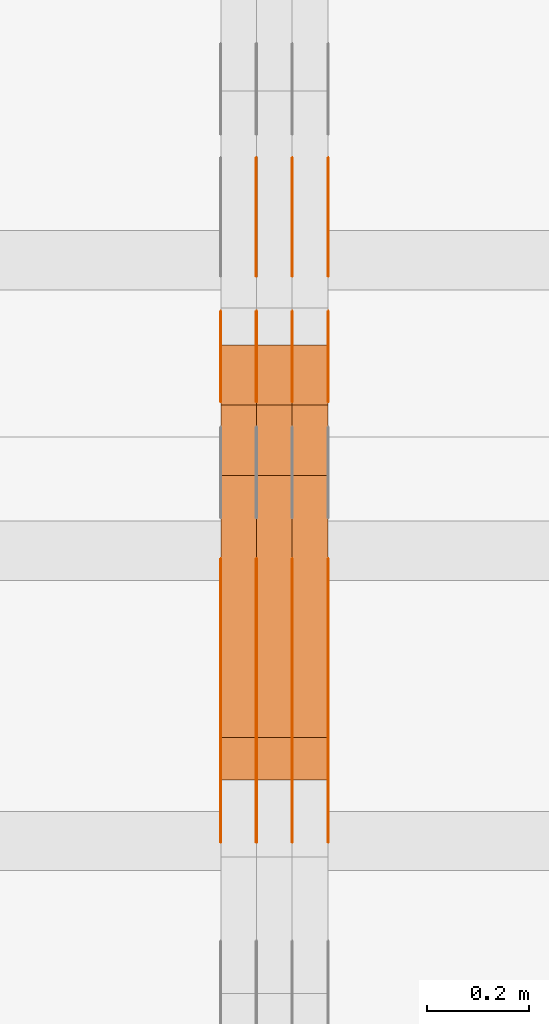
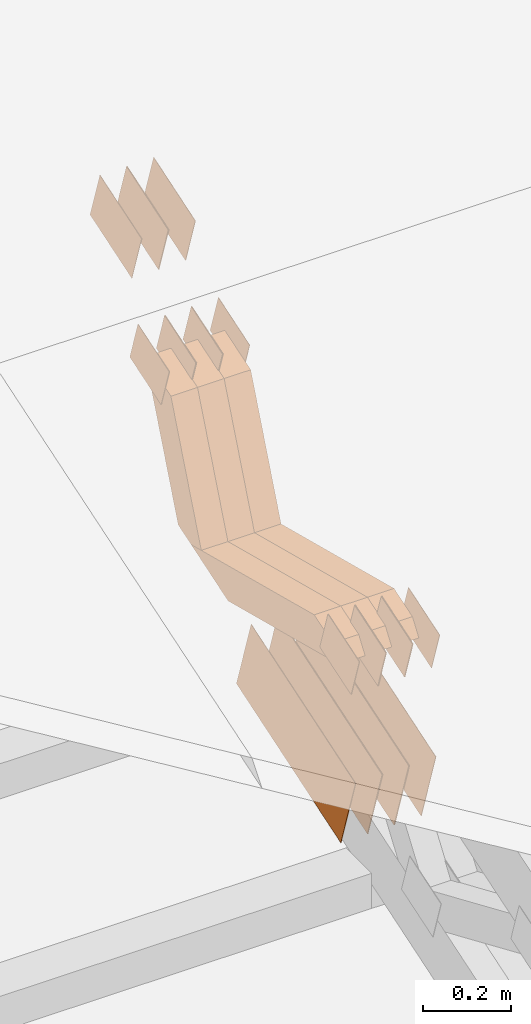
# One storey, part 119 of 385: 28 proxies.
"""IFC2X3 building model written with IfcOpenShell, lengths in millimetres."""

from ifc_helpers import new_model, entity, si_unit, converted_unit, derived_unit, direction, frame, origin, place, context, subcontext, project, spatial, polyline, outline, extrude, source, transform, mapped, material, type_object, type_shapes, element, save


model = new_model("IFC2X3")

# Units and contexts
model_context = context("Model", 3, precision=0.01, world=origin(), true_north=direction((6.12303176911189e-17, 1.0)))
body_context = subcontext(model_context, "Body", "Model", "MODEL_VIEW")
ifc_project = project(units=[si_unit("LENGTHUNIT", "METRE", prefix="MILLI"), si_unit("AREAUNIT", "SQUARE_METRE"), si_unit("VOLUMEUNIT", "CUBIC_METRE"), converted_unit("PLANEANGLEUNIT", "DEGREE", entity("IfcRatioMeasure", 0.0174532925199433), si_unit("PLANEANGLEUNIT", "RADIAN"), dimensions=[0, 0, 0, 0, 0, 0, 0]), si_unit("MASSUNIT", "GRAM", prefix="KILO"), derived_unit("MASSDENSITYUNIT", [(si_unit("MASSUNIT", "GRAM", prefix="KILO"), 1), (si_unit("LENGTHUNIT", "METRE"), -3)]), si_unit("TIMEUNIT", "SECOND"), si_unit("FREQUENCYUNIT", "HERTZ"), si_unit("THERMODYNAMICTEMPERATUREUNIT", "DEGREE_CELSIUS"), derived_unit("THERMALTRANSMITTANCEUNIT", [(si_unit("MASSUNIT", "GRAM", prefix="KILO"), 1), (si_unit("THERMODYNAMICTEMPERATUREUNIT", "KELVIN"), -1), (si_unit("TIMEUNIT", "SECOND"), -3)]), derived_unit("VOLUMETRICFLOWRATEUNIT", [(si_unit("LENGTHUNIT", "METRE"), 3), (si_unit("TIMEUNIT", "SECOND"), -1)]), si_unit("ELECTRICCURRENTUNIT", "AMPERE"), si_unit("ELECTRICVOLTAGEUNIT", "VOLT"), si_unit("POWERUNIT", "WATT"), si_unit("FORCEUNIT", "NEWTON", prefix="KILO"), si_unit("ILLUMINANCEUNIT", "LUX"), si_unit("LUMINOUSFLUXUNIT", "LUMEN"), si_unit("LUMINOUSINTENSITYUNIT", "CANDELA"), derived_unit("USERDEFINED", [(si_unit("MASSUNIT", "GRAM", prefix="KILO"), -1), (si_unit("LENGTHUNIT", "METRE"), -2), (si_unit("TIMEUNIT", "SECOND"), 3), (si_unit("LUMINOUSFLUXUNIT", "LUMEN"), 1)]), derived_unit("LINEARVELOCITYUNIT", [(si_unit("LENGTHUNIT", "METRE"), 1), (si_unit("TIMEUNIT", "SECOND"), -1)]), si_unit("PRESSUREUNIT", "PASCAL"), derived_unit("USERDEFINED", [(si_unit("LENGTHUNIT", "METRE"), -2), (si_unit("MASSUNIT", "GRAM", prefix="KILO"), 1), (si_unit("TIMEUNIT", "SECOND"), -2)])], contexts=[model_context])

# Site, building, storey
site_placement = place(None, origin())
site = spatial("IfcSite", under=ifc_project, at=site_placement, CompositionType="ELEMENT")
building_placement = place(site_placement, origin())
building = spatial("IfcBuilding", under=site, at=building_placement, CompositionType="ELEMENT")
storey_placement = place(building_placement, origin())
storey = spatial("IfcBuildingStorey", under=building, at=storey_placement, Name="Default", CompositionType="ELEMENT", Elevation=0.0)

# Proxies
ifc_material_1 = material(Name="IfcSurfaceStyle #281424")
building_element_proxy_type_1 = type_object("IfcBuildingElementProxyType", PredefinedType="NOTDEFINED", material=ifc_material_1)
shared_shape_1 = source(origin(), body_context, "Body", "SweptSolid", [
    extrude(outline(polyline([(-74.9998754286225, -60.0000016373515), (74.9998605591045, -60.0000016373515), (74.9998754286225, 60.0000016373515), (-74.9998605591045, 60.0000016373515), (-74.9998754286225, -60.0000016373515)])), frame((74.9998754286225, 60.0000016373515, 0.0), z_axis=(0.0, 0.0, 1.0), x_axis=(-1.0, 0.0, 0.0)), (0.0, 0.0, 1.0), 1.3),
])
type_shapes(building_element_proxy_type_1, [shared_shape_1])
proxy_1_placement = place(building_placement, frame((21386.3, 8765.47458614632, 2350.86432930304), z_axis=(-1.0, 0.0, 0.0), x_axis=(0.0, 0.951056516295154, 0.309016994374948)))
element("IfcBuildingElementProxy", 1, at=proxy_1_placement, inside=storey, type_object=building_element_proxy_type_1, material=ifc_material_1, context=body_context, shape_type="MappedRepresentation", body=[
    mapped(shared_shape_1, transform((0.0, 0.0, 0.0), scale=1.0)),
])
ifc_material_2 = material(Name="IfcSurfaceStyle #281367")
building_element_proxy_type_2 = type_object("IfcBuildingElementProxyType", PredefinedType="NOTDEFINED", material=ifc_material_2)
shared_shape_2 = source(origin(), body_context, "Body", "SweptSolid", [
    extrude(outline(polyline([(-74.9998754286225, -60.0000016373515), (74.9998605591045, -60.0000016373515), (74.9998754286225, 60.0000016373515), (-74.9998605591045, 60.0000016373515), (-74.9998754286225, -60.0000016373515)])), frame((74.9998754286225, 60.0000016373515, 0.0), z_axis=(0.0, 0.0, 1.0), x_axis=(-1.0, 0.0, 0.0)), (0.0, 0.0, 1.0), 1.3),
])
type_shapes(building_element_proxy_type_2, [shared_shape_2])
proxy_2_placement = place(building_placement, frame((21315.0, 8765.47458614632, 2350.86432930304), z_axis=(-1.0, 0.0, 0.0), x_axis=(0.0, 0.951056516295154, 0.309016994374948)))
element("IfcBuildingElementProxy", 2, at=proxy_2_placement, inside=storey, type_object=building_element_proxy_type_2, material=ifc_material_2, context=body_context, shape_type="MappedRepresentation", body=[
    mapped(shared_shape_2, transform((0.0, 0.0, 0.0), scale=1.0)),
])
ifc_material_3 = material(Name="IfcSurfaceStyle #281310")
building_element_proxy_type_3 = type_object("IfcBuildingElementProxyType", PredefinedType="NOTDEFINED", material=ifc_material_3)
shared_shape_3 = source(origin(), body_context, "Body", "SweptSolid", [
    extrude(outline(polyline([(-74.9998754286225, -60.0000016373515), (74.9998605591045, -60.0000016373515), (74.9998754286225, 60.0000016373515), (-74.9998605591045, 60.0000016373515), (-74.9998754286225, -60.0000016373515)])), frame((74.9998754286225, 60.0000016373515, 0.0), z_axis=(0.0, 0.0, 1.0), x_axis=(-1.0, 0.0, 0.0)), (0.0, 0.0, 1.0), 1.3),
])
type_shapes(building_element_proxy_type_3, [shared_shape_3])
proxy_3_placement = place(building_placement, frame((21316.3, 8765.47458614632, 2350.86432930304), z_axis=(-1.0, 0.0, 0.0), x_axis=(0.0, 0.951056516295154, 0.309016994374948)))
element("IfcBuildingElementProxy", 3, at=proxy_3_placement, inside=storey, type_object=building_element_proxy_type_3, material=ifc_material_3, context=body_context, shape_type="MappedRepresentation", body=[
    mapped(shared_shape_3, transform((0.0, 0.0, 0.0), scale=1.0)),
])
ifc_material_4 = material(Name="IfcSurfaceStyle #281253")
building_element_proxy_type_4 = type_object("IfcBuildingElementProxyType", PredefinedType="NOTDEFINED", material=ifc_material_4)
shared_shape_4 = source(origin(), body_context, "Body", "SweptSolid", [
    extrude(outline(polyline([(-74.9998754286225, -60.0000016373515), (74.9998605591045, -60.0000016373515), (74.9998754286225, 60.0000016373515), (-74.9998605591045, 60.0000016373515), (-74.9998754286225, -60.0000016373515)])), frame((74.9998754286225, 60.0000016373515, 0.0), z_axis=(0.0, 0.0, 1.0), x_axis=(-1.0, 0.0, 0.0)), (0.0, 0.0, 1.0), 1.29999999999999),
])
type_shapes(building_element_proxy_type_4, [shared_shape_4])
proxy_4_placement = place(building_placement, frame((21245.0, 8765.47458614632, 2350.86432930304), z_axis=(-1.0, 0.0, 0.0), x_axis=(0.0, 0.951056516295154, 0.309016994374948)))
element("IfcBuildingElementProxy", 4, at=proxy_4_placement, inside=storey, type_object=building_element_proxy_type_4, material=ifc_material_4, context=body_context, shape_type="MappedRepresentation", body=[
    mapped(shared_shape_4, transform((0.0, 0.0, 0.0), scale=1.0)),
])
ifc_material_5 = material(Name="IfcSurfaceStyle #281196")
building_element_proxy_type_5 = type_object("IfcBuildingElementProxyType", PredefinedType="NOTDEFINED", material=ifc_material_5)
shared_shape_5 = source(origin(), body_context, "Body", "SweptSolid", [
    extrude(outline(polyline([(-74.9998754286225, -60.0000016373515), (74.9998605591045, -60.0000016373515), (74.9998754286225, 60.0000016373515), (-74.9998605591045, 60.0000016373515), (-74.9998754286225, -60.0000016373515)])), frame((74.9998754286225, 60.0000016373515, 0.0), z_axis=(0.0, 0.0, 1.0), x_axis=(-1.0, 0.0, 0.0)), (0.0, 0.0, 1.0), 1.29999999999999),
])
type_shapes(building_element_proxy_type_5, [shared_shape_5])
proxy_5_placement = place(building_placement, frame((21246.3, 8765.47458614632, 2350.86432930304), z_axis=(-1.0, 0.0, 0.0), x_axis=(0.0, 0.951056516295154, 0.309016994374948)))
element("IfcBuildingElementProxy", 5, at=proxy_5_placement, inside=storey, type_object=building_element_proxy_type_5, material=ifc_material_5, context=body_context, shape_type="MappedRepresentation", body=[
    mapped(shared_shape_5, transform((0.0, 0.0, 0.0), scale=1.0)),
])
ifc_material_6 = material(Name="IfcSurfaceStyle #281139")
building_element_proxy_type_6 = type_object("IfcBuildingElementProxyType", PredefinedType="NOTDEFINED", material=ifc_material_6)
shared_shape_6 = source(origin(), body_context, "Body", "SweptSolid", [
    extrude(outline(polyline([(-74.9998754286225, -60.0000016373515), (74.9998605591045, -60.0000016373515), (74.9998754286225, 60.0000016373515), (-74.9998605591045, 60.0000016373515), (-74.9998754286225, -60.0000016373515)])), frame((74.9998754286225, 60.0000016373515, 0.0), z_axis=(0.0, 0.0, 1.0), x_axis=(-1.0, 0.0, 0.0)), (0.0, 0.0, 1.0), 1.29999999999999),
])
type_shapes(building_element_proxy_type_6, [shared_shape_6])
proxy_6_placement = place(building_placement, frame((21175.0, 8765.47458614632, 2350.86432930304), z_axis=(-1.0, 0.0, 0.0), x_axis=(0.0, 0.951056516295154, 0.309016994374948)))
element("IfcBuildingElementProxy", 6, at=proxy_6_placement, inside=storey, type_object=building_element_proxy_type_6, material=ifc_material_6, context=body_context, shape_type="MappedRepresentation", body=[
    mapped(shared_shape_6, transform((0.0, 0.0, 0.0), scale=1.0)),
])
ifc_material_7 = material(Name="IfcSurfaceStyle #280740")
building_element_proxy_type_7 = type_object("IfcBuildingElementProxyType", PredefinedType="NOTDEFINED", material=ifc_material_7)
shared_shape_7 = source(origin(), body_context, "Body", "SweptSolid", [
    extrude(outline(polyline([(-249.999749056184, -108.000229288163), (249.999396050782, -108.000229288163), (249.999749056184, 108.000229288163), (-249.999396050782, 108.000229288163), (-249.999749056184, -108.000229288163)])), frame((249.999841104007, 108.000229288163, 0.0), z_axis=(0.0, 0.0, 1.0), x_axis=(-1.0, 0.0, 0.0)), (0.0, 0.0, 1.0), 1.29999999999998),
])
type_shapes(building_element_proxy_type_7, [shared_shape_7])
proxy_7_placement = place(building_placement, frame((21386.3, 7917.13457673635, 1720.66532252899), z_axis=(-1.0, 0.0, 0.0), x_axis=(0.0, 0.951056516295124, 0.309016994375039)))
element("IfcBuildingElementProxy", 7, at=proxy_7_placement, inside=storey, type_object=building_element_proxy_type_7, material=ifc_material_7, context=body_context, shape_type="MappedRepresentation", body=[
    mapped(shared_shape_7, transform((0.0, 0.0, 0.0), scale=1.0)),
])
ifc_material_8 = material(Name="IfcSurfaceStyle #280683")
building_element_proxy_type_8 = type_object("IfcBuildingElementProxyType", PredefinedType="NOTDEFINED", material=ifc_material_8)
shared_shape_8 = source(origin(), body_context, "Body", "SweptSolid", [
    extrude(outline(polyline([(-249.999749056184, -108.000229288163), (249.999396050782, -108.000229288163), (249.999749056184, 108.000229288163), (-249.999396050782, 108.000229288163), (-249.999749056184, -108.000229288163)])), frame((249.999841104007, 108.000229288163, 0.0), z_axis=(0.0, 0.0, 1.0), x_axis=(-1.0, 0.0, 0.0)), (0.0, 0.0, 1.0), 1.29999999999998),
])
type_shapes(building_element_proxy_type_8, [shared_shape_8])
proxy_8_placement = place(building_placement, frame((21315.0, 7917.13457673635, 1720.66532252899), z_axis=(-1.0, 0.0, 0.0), x_axis=(0.0, 0.951056516295124, 0.309016994375039)))
element("IfcBuildingElementProxy", 8, at=proxy_8_placement, inside=storey, type_object=building_element_proxy_type_8, material=ifc_material_8, context=body_context, shape_type="MappedRepresentation", body=[
    mapped(shared_shape_8, transform((0.0, 0.0, 0.0), scale=1.0)),
])
ifc_material_9 = material(Name="IfcSurfaceStyle #280626")
building_element_proxy_type_9 = type_object("IfcBuildingElementProxyType", PredefinedType="NOTDEFINED", material=ifc_material_9)
shared_shape_9 = source(origin(), body_context, "Body", "SweptSolid", [
    extrude(outline(polyline([(-249.999749056184, -108.000229288163), (249.999396050782, -108.000229288163), (249.999749056184, 108.000229288163), (-249.999396050782, 108.000229288163), (-249.999749056184, -108.000229288163)])), frame((249.999841104007, 108.000229288163, 0.0), z_axis=(0.0, 0.0, 1.0), x_axis=(-1.0, 0.0, 0.0)), (0.0, 0.0, 1.0), 1.29999999999998),
])
type_shapes(building_element_proxy_type_9, [shared_shape_9])
proxy_9_placement = place(building_placement, frame((21316.3, 7917.13457673635, 1720.66532252899), z_axis=(-1.0, 0.0, 0.0), x_axis=(0.0, 0.951056516295124, 0.309016994375039)))
element("IfcBuildingElementProxy", 9, at=proxy_9_placement, inside=storey, type_object=building_element_proxy_type_9, material=ifc_material_9, context=body_context, shape_type="MappedRepresentation", body=[
    mapped(shared_shape_9, transform((0.0, 0.0, 0.0), scale=1.0)),
])
ifc_material_10 = material(Name="IfcSurfaceStyle #280569")
building_element_proxy_type_10 = type_object("IfcBuildingElementProxyType", PredefinedType="NOTDEFINED", material=ifc_material_10)
shared_shape_10 = source(origin(), body_context, "Body", "SweptSolid", [
    extrude(outline(polyline([(-249.999749056184, -108.000229288163), (249.999396050782, -108.000229288163), (249.999749056184, 108.000229288163), (-249.999396050782, 108.000229288163), (-249.999749056184, -108.000229288163)])), frame((249.999841104007, 108.000229288163, 0.0), z_axis=(0.0, 0.0, 1.0), x_axis=(-1.0, 0.0, 0.0)), (0.0, 0.0, 1.0), 1.29999999999997),
])
type_shapes(building_element_proxy_type_10, [shared_shape_10])
proxy_10_placement = place(building_placement, frame((21245.0, 7917.13457673635, 1720.66532252899), z_axis=(-1.0, 0.0, 0.0), x_axis=(0.0, 0.951056516295124, 0.309016994375039)))
element("IfcBuildingElementProxy", 10, at=proxy_10_placement, inside=storey, type_object=building_element_proxy_type_10, material=ifc_material_10, context=body_context, shape_type="MappedRepresentation", body=[
    mapped(shared_shape_10, transform((0.0, 0.0, 0.0), scale=1.0)),
])
ifc_material_11 = material(Name="IfcSurfaceStyle #280512")
building_element_proxy_type_11 = type_object("IfcBuildingElementProxyType", PredefinedType="NOTDEFINED", material=ifc_material_11)
shared_shape_11 = source(origin(), body_context, "Body", "SweptSolid", [
    extrude(outline(polyline([(-249.999749056184, -108.000229288163), (249.999396050782, -108.000229288163), (249.999749056184, 108.000229288163), (-249.999396050782, 108.000229288163), (-249.999749056184, -108.000229288163)])), frame((249.999841104007, 108.000229288163, 0.0), z_axis=(0.0, 0.0, 1.0), x_axis=(-1.0, 0.0, 0.0)), (0.0, 0.0, 1.0), 1.29999999999997),
])
type_shapes(building_element_proxy_type_11, [shared_shape_11])
proxy_11_placement = place(building_placement, frame((21246.3, 7917.13457673635, 1720.66532252899), z_axis=(-1.0, 0.0, 0.0), x_axis=(0.0, 0.951056516295124, 0.309016994375039)))
element("IfcBuildingElementProxy", 11, at=proxy_11_placement, inside=storey, type_object=building_element_proxy_type_11, material=ifc_material_11, context=body_context, shape_type="MappedRepresentation", body=[
    mapped(shared_shape_11, transform((0.0, 0.0, 0.0), scale=1.0)),
])
ifc_material_12 = material(Name="IfcSurfaceStyle #280455")
building_element_proxy_type_12 = type_object("IfcBuildingElementProxyType", PredefinedType="NOTDEFINED", material=ifc_material_12)
shared_shape_12 = source(origin(), body_context, "Body", "SweptSolid", [
    extrude(outline(polyline([(-249.999749056184, -108.000229288163), (249.999396050782, -108.000229288163), (249.999749056184, 108.000229288163), (-249.999396050782, 108.000229288163), (-249.999749056184, -108.000229288163)])), frame((249.999841104007, 108.000229288163, 0.0), z_axis=(0.0, 0.0, 1.0), x_axis=(-1.0, 0.0, 0.0)), (0.0, 0.0, 1.0), 1.29999999999997),
])
type_shapes(building_element_proxy_type_12, [shared_shape_12])
proxy_12_placement = place(building_placement, frame((21175.0, 7917.13457673635, 1720.66532252899), z_axis=(-1.0, 0.0, 0.0), x_axis=(0.0, 0.951056516295124, 0.309016994375039)))
element("IfcBuildingElementProxy", 12, at=proxy_12_placement, inside=storey, type_object=building_element_proxy_type_12, material=ifc_material_12, context=body_context, shape_type="MappedRepresentation", body=[
    mapped(shared_shape_12, transform((0.0, 0.0, 0.0), scale=1.0)),
])
ifc_material_13 = material(Name="IfcSurfaceStyle #280398")
building_element_proxy_type_13 = type_object("IfcBuildingElementProxyType", PredefinedType="NOTDEFINED", material=ifc_material_13)
shared_shape_13 = source(origin(), body_context, "Body", "SweptSolid", [
    extrude(outline(polyline([(-99.999644645517, -72.0000317581407), (100.000028485991, -72.0000317581407), (99.999644645517, 72.0000317581407), (-100.000028485991, 72.0000317581407), (-99.999644645517, -72.0000317581407)])), frame((100.000028485991, 72.0000317581407, 0.0), z_axis=(0.0, 0.0, 1.0), x_axis=(-1.0, 0.0, 0.0)), (0.0, 0.0, 1.0), 1.3),
])
type_shapes(building_element_proxy_type_13, [shared_shape_13])
proxy_13_placement = place(building_placement, frame((21386.3, 9012.6304394324, 2546.30522609783), z_axis=(-1.0, 0.0, 0.0), x_axis=(0.0, 0.951056516295154, 0.309016994374948)))
element("IfcBuildingElementProxy", 13, at=proxy_13_placement, inside=storey, type_object=building_element_proxy_type_13, material=ifc_material_13, context=body_context, shape_type="MappedRepresentation", body=[
    mapped(shared_shape_13, transform((0.0, 0.0, 0.0), scale=1.0)),
])
ifc_material_14 = material(Name="IfcSurfaceStyle #280341")
building_element_proxy_type_14 = type_object("IfcBuildingElementProxyType", PredefinedType="NOTDEFINED", material=ifc_material_14)
shared_shape_14 = source(origin(), body_context, "Body", "SweptSolid", [
    extrude(outline(polyline([(-99.999644645517, -72.0000317581407), (100.000028485991, -72.0000317581407), (99.999644645517, 72.0000317581407), (-100.000028485991, 72.0000317581407), (-99.999644645517, -72.0000317581407)])), frame((100.000028485991, 72.0000317581407, 0.0), z_axis=(0.0, 0.0, 1.0), x_axis=(-1.0, 0.0, 0.0)), (0.0, 0.0, 1.0), 1.3),
])
type_shapes(building_element_proxy_type_14, [shared_shape_14])
proxy_14_placement = place(building_placement, frame((21315.0, 9012.6304394324, 2546.30522609783), z_axis=(-1.0, 0.0, 0.0), x_axis=(0.0, 0.951056516295154, 0.309016994374948)))
element("IfcBuildingElementProxy", 14, at=proxy_14_placement, inside=storey, type_object=building_element_proxy_type_14, material=ifc_material_14, context=body_context, shape_type="MappedRepresentation", body=[
    mapped(shared_shape_14, transform((0.0, 0.0, 0.0), scale=1.0)),
])
ifc_material_15 = material(Name="IfcSurfaceStyle #280284")
building_element_proxy_type_15 = type_object("IfcBuildingElementProxyType", PredefinedType="NOTDEFINED", material=ifc_material_15)
shared_shape_15 = source(origin(), body_context, "Body", "SweptSolid", [
    extrude(outline(polyline([(-99.999644645517, -72.0000317581407), (100.000028485991, -72.0000317581407), (99.999644645517, 72.0000317581407), (-100.000028485991, 72.0000317581407), (-99.999644645517, -72.0000317581407)])), frame((100.000028485991, 72.0000317581407, 0.0), z_axis=(0.0, 0.0, 1.0), x_axis=(-1.0, 0.0, 0.0)), (0.0, 0.0, 1.0), 1.3),
])
type_shapes(building_element_proxy_type_15, [shared_shape_15])
proxy_15_placement = place(building_placement, frame((21316.3, 9012.6304394324, 2546.30522609783), z_axis=(-1.0, 0.0, 0.0), x_axis=(0.0, 0.951056516295154, 0.309016994374948)))
element("IfcBuildingElementProxy", 15, at=proxy_15_placement, inside=storey, type_object=building_element_proxy_type_15, material=ifc_material_15, context=body_context, shape_type="MappedRepresentation", body=[
    mapped(shared_shape_15, transform((0.0, 0.0, 0.0), scale=1.0)),
])
ifc_material_16 = material(Name="IfcSurfaceStyle #280227")
building_element_proxy_type_16 = type_object("IfcBuildingElementProxyType", PredefinedType="NOTDEFINED", material=ifc_material_16)
shared_shape_16 = source(origin(), body_context, "Body", "SweptSolid", [
    extrude(outline(polyline([(-99.999644645517, -72.0000317581407), (100.000028485991, -72.0000317581407), (99.999644645517, 72.0000317581407), (-100.000028485991, 72.0000317581407), (-99.999644645517, -72.0000317581407)])), frame((100.000028485991, 72.0000317581407, 0.0), z_axis=(0.0, 0.0, 1.0), x_axis=(-1.0, 0.0, 0.0)), (0.0, 0.0, 1.0), 1.29999999999998),
])
type_shapes(building_element_proxy_type_16, [shared_shape_16])
proxy_16_placement = place(building_placement, frame((21245.0, 9012.6304394324, 2546.30522609783), z_axis=(-1.0, 0.0, 0.0), x_axis=(0.0, 0.951056516295154, 0.309016994374948)))
element("IfcBuildingElementProxy", 16, at=proxy_16_placement, inside=storey, type_object=building_element_proxy_type_16, material=ifc_material_16, context=body_context, shape_type="MappedRepresentation", body=[
    mapped(shared_shape_16, transform((0.0, 0.0, 0.0), scale=1.0)),
])
ifc_material_17 = material(Name="IfcSurfaceStyle #267060")
building_element_proxy_type_17 = type_object("IfcBuildingElementProxyType", PredefinedType="NOTDEFINED", material=ifc_material_17)
shared_shape_17 = source(origin(), body_context, "Body", "SweptSolid", [
    extrude(outline(polyline([(-74.9998754286253, -60.0000016373506), (74.9998605591091, -60.0000016373506), (74.9998754286234, 60.0000016373506), (-74.9998605591072, 60.0000016373506), (-74.9998754286253, -60.0000016373506)])), frame((75.0007355357002, 60.0002637031812, 0.0), z_axis=(0.0, 0.0, 1.0), x_axis=(-1.0, 0.0, 0.0)), (0.0, 0.0, 1.0), 1.3),
])
type_shapes(building_element_proxy_type_17, [shared_shape_17])
proxy_17_placement = place(building_placement, frame((21386.3, 7899.79204652808, 2069.58672486412), z_axis=(-1.0, 0.0, 0.0), x_axis=(0.0, 0.951056516295154, 0.309016994374948)))
element("IfcBuildingElementProxy", 17, at=proxy_17_placement, inside=storey, type_object=building_element_proxy_type_17, material=ifc_material_17, context=body_context, shape_type="MappedRepresentation", body=[
    mapped(shared_shape_17, transform((0.0, 0.0, 0.0), scale=1.0)),
])
ifc_material_18 = material(Name="IfcSurfaceStyle #267003")
building_element_proxy_type_18 = type_object("IfcBuildingElementProxyType", PredefinedType="NOTDEFINED", material=ifc_material_18)
shared_shape_18 = source(origin(), body_context, "Body", "SweptSolid", [
    extrude(outline(polyline([(-74.9998754286253, -60.0000016373506), (74.9998605591091, -60.0000016373506), (74.9998754286234, 60.0000016373506), (-74.9998605591072, 60.0000016373506), (-74.9998754286253, -60.0000016373506)])), frame((75.0007355357002, 60.0002637031812, 0.0), z_axis=(0.0, 0.0, 1.0), x_axis=(-1.0, 0.0, 0.0)), (0.0, 0.0, 1.0), 1.3),
])
type_shapes(building_element_proxy_type_18, [shared_shape_18])
proxy_18_placement = place(building_placement, frame((21315.0, 7899.79204652808, 2069.58672486412), z_axis=(-1.0, 0.0, 0.0), x_axis=(0.0, 0.951056516295154, 0.309016994374948)))
element("IfcBuildingElementProxy", 18, at=proxy_18_placement, inside=storey, type_object=building_element_proxy_type_18, material=ifc_material_18, context=body_context, shape_type="MappedRepresentation", body=[
    mapped(shared_shape_18, transform((0.0, 0.0, 0.0), scale=1.0)),
])
ifc_material_19 = material(Name="IfcSurfaceStyle #266946")
building_element_proxy_type_19 = type_object("IfcBuildingElementProxyType", PredefinedType="NOTDEFINED", material=ifc_material_19)
shared_shape_19 = source(origin(), body_context, "Body", "SweptSolid", [
    extrude(outline(polyline([(-74.9998754286253, -60.0000016373506), (74.9998605591091, -60.0000016373506), (74.9998754286234, 60.0000016373506), (-74.9998605591072, 60.0000016373506), (-74.9998754286253, -60.0000016373506)])), frame((75.0007355357002, 60.0002637031812, 0.0), z_axis=(0.0, 0.0, 1.0), x_axis=(-1.0, 0.0, 0.0)), (0.0, 0.0, 1.0), 1.3),
])
type_shapes(building_element_proxy_type_19, [shared_shape_19])
proxy_19_placement = place(building_placement, frame((21316.3, 7899.79204652808, 2069.58672486412), z_axis=(-1.0, 0.0, 0.0), x_axis=(0.0, 0.951056516295154, 0.309016994374948)))
element("IfcBuildingElementProxy", 19, at=proxy_19_placement, inside=storey, type_object=building_element_proxy_type_19, material=ifc_material_19, context=body_context, shape_type="MappedRepresentation", body=[
    mapped(shared_shape_19, transform((0.0, 0.0, 0.0), scale=1.0)),
])
ifc_material_20 = material(Name="IfcSurfaceStyle #266889")
building_element_proxy_type_20 = type_object("IfcBuildingElementProxyType", PredefinedType="NOTDEFINED", material=ifc_material_20)
shared_shape_20 = source(origin(), body_context, "Body", "SweptSolid", [
    extrude(outline(polyline([(-74.9998754286253, -60.0000016373506), (74.9998605591091, -60.0000016373506), (74.9998754286234, 60.0000016373506), (-74.9998605591072, 60.0000016373506), (-74.9998754286253, -60.0000016373506)])), frame((75.0007355357002, 60.0002637031812, 0.0), z_axis=(0.0, 0.0, 1.0), x_axis=(-1.0, 0.0, 0.0)), (0.0, 0.0, 1.0), 1.29999999999999),
])
type_shapes(building_element_proxy_type_20, [shared_shape_20])
proxy_20_placement = place(building_placement, frame((21245.0, 7899.79204652808, 2069.58672486412), z_axis=(-1.0, 0.0, 0.0), x_axis=(0.0, 0.951056516295154, 0.309016994374948)))
element("IfcBuildingElementProxy", 20, at=proxy_20_placement, inside=storey, type_object=building_element_proxy_type_20, material=ifc_material_20, context=body_context, shape_type="MappedRepresentation", body=[
    mapped(shared_shape_20, transform((0.0, 0.0, 0.0), scale=1.0)),
])
ifc_material_21 = material(Name="IfcSurfaceStyle #266832")
building_element_proxy_type_21 = type_object("IfcBuildingElementProxyType", PredefinedType="NOTDEFINED", material=ifc_material_21)
shared_shape_21 = source(origin(), body_context, "Body", "SweptSolid", [
    extrude(outline(polyline([(-74.9998754286253, -60.0000016373506), (74.9998605591091, -60.0000016373506), (74.9998754286234, 60.0000016373506), (-74.9998605591072, 60.0000016373506), (-74.9998754286253, -60.0000016373506)])), frame((75.0007355357002, 60.0002637031812, 0.0), z_axis=(0.0, 0.0, 1.0), x_axis=(-1.0, 0.0, 0.0)), (0.0, 0.0, 1.0), 1.29999999999999),
])
type_shapes(building_element_proxy_type_21, [shared_shape_21])
proxy_21_placement = place(building_placement, frame((21246.3, 7899.79204652808, 2069.58672486412), z_axis=(-1.0, 0.0, 0.0), x_axis=(0.0, 0.951056516295154, 0.309016994374948)))
element("IfcBuildingElementProxy", 21, at=proxy_21_placement, inside=storey, type_object=building_element_proxy_type_21, material=ifc_material_21, context=body_context, shape_type="MappedRepresentation", body=[
    mapped(shared_shape_21, transform((0.0, 0.0, 0.0), scale=1.0)),
])
ifc_material_22 = material(Name="IfcSurfaceStyle #266775")
building_element_proxy_type_22 = type_object("IfcBuildingElementProxyType", PredefinedType="NOTDEFINED", material=ifc_material_22)
shared_shape_22 = source(origin(), body_context, "Body", "SweptSolid", [
    extrude(outline(polyline([(-74.9998754286253, -60.0000016373506), (74.9998605591091, -60.0000016373506), (74.9998754286234, 60.0000016373506), (-74.9998605591072, 60.0000016373506), (-74.9998754286253, -60.0000016373506)])), frame((75.0007355357002, 60.0002637031812, 0.0), z_axis=(0.0, 0.0, 1.0), x_axis=(-1.0, 0.0, 0.0)), (0.0, 0.0, 1.0), 1.29999999999999),
])
type_shapes(building_element_proxy_type_22, [shared_shape_22])
proxy_22_placement = place(building_placement, frame((21175.0, 7899.79204652808, 2069.58672486412), z_axis=(-1.0, 0.0, 0.0), x_axis=(0.0, 0.951056516295154, 0.309016994374948)))
element("IfcBuildingElementProxy", 22, at=proxy_22_placement, inside=storey, type_object=building_element_proxy_type_22, material=ifc_material_22, context=body_context, shape_type="MappedRepresentation", body=[
    mapped(shared_shape_22, transform((0.0, 0.0, 0.0), scale=1.0)),
])
ifc_material_23 = material(Name="IfcSurfaceStyle #254676")
building_element_proxy_type_23 = type_object("IfcBuildingElementProxyType", Name="T1-W45 254674", PredefinedType="NOTDEFINED", material=ifc_material_23)
shared_shape_23 = source(origin(), body_context, "Body", "SweptSolid", [
    extrude(outline(polyline([(-275.953018340717, -47.500197738425), (128.971267956636, -47.5001977384251), (168.669977842085, -0.000132525443043008), (174.867371111815, 47.5002640011466), (-196.55559856982, 47.5002640011466), (-275.953018340717, -47.500197738425)])), frame((174.867371111815, 47.5002640011466, 0.0), z_axis=(0.0, 0.0, 1.0), x_axis=(-1.0, 0.0, 0.0)), (0.0, 0.0, 1.0), 70.0),
])
type_shapes(building_element_proxy_type_23, [shared_shape_23])
proxy_23_placement = place(building_placement, frame((21385.0, 8621.494140625, 1941.33422851563), z_axis=(-1.0, 0.0, 0.0), x_axis=(0.0, 0.372787901688292, 0.927916580493549)))
element("IfcBuildingElementProxy", 23, at=proxy_23_placement, inside=storey, type_object=building_element_proxy_type_23, material=ifc_material_23, Name="T1-W45", context=body_context, shape_type="MappedRepresentation", body=[
    mapped(shared_shape_23, transform((0.0, 0.0, 0.0), scale=1.0)),
])
ifc_material_24 = material(Name="IfcSurfaceStyle #254610")
building_element_proxy_type_24 = type_object("IfcBuildingElementProxyType", Name="T1-W45 254608", PredefinedType="NOTDEFINED", material=ifc_material_24)
shared_shape_24 = source(origin(), body_context, "Body", "SweptSolid", [
    extrude(outline(polyline([(-275.953018340717, -47.500197738425), (128.971267956636, -47.5001977384251), (168.669977842085, -0.000132525443043008), (174.867371111815, 47.5002640011466), (-196.55559856982, 47.5002640011466), (-275.953018340717, -47.500197738425)])), frame((174.867371111815, 47.5002640011466, 0.0), z_axis=(0.0, 0.0, 1.0), x_axis=(-1.0, 0.0, 0.0)), (0.0, 0.0, 1.0), 70.0),
])
type_shapes(building_element_proxy_type_24, [shared_shape_24])
proxy_24_placement = place(building_placement, frame((21315.0, 8621.494140625, 1941.33422851563), z_axis=(-1.0, 0.0, 0.0), x_axis=(0.0, 0.372787901688292, 0.927916580493549)))
element("IfcBuildingElementProxy", 24, at=proxy_24_placement, inside=storey, type_object=building_element_proxy_type_24, material=ifc_material_24, Name="T1-W45", context=body_context, shape_type="MappedRepresentation", body=[
    mapped(shared_shape_24, transform((0.0, 0.0, 0.0), scale=1.0)),
])
ifc_material_25 = material(Name="IfcSurfaceStyle #254544")
building_element_proxy_type_25 = type_object("IfcBuildingElementProxyType", Name="T1-W45 254542", PredefinedType="NOTDEFINED", material=ifc_material_25)
shared_shape_25 = source(origin(), body_context, "Body", "SweptSolid", [
    extrude(outline(polyline([(-275.953018340717, -47.500197738425), (128.971267956636, -47.5001977384251), (168.669977842085, -0.000132525443043008), (174.867371111815, 47.5002640011466), (-196.55559856982, 47.5002640011466), (-275.953018340717, -47.500197738425)])), frame((174.867371111815, 47.5002640011466, 0.0), z_axis=(0.0, 0.0, 1.0), x_axis=(-1.0, 0.0, 0.0)), (0.0, 0.0, 1.0), 70.0),
])
type_shapes(building_element_proxy_type_25, [shared_shape_25])
proxy_25_placement = place(building_placement, frame((21245.0, 8621.494140625, 1941.33422851563), z_axis=(-1.0, 0.0, 0.0), x_axis=(0.0, 0.372787901688292, 0.927916580493549)))
element("IfcBuildingElementProxy", 25, at=proxy_25_placement, inside=storey, type_object=building_element_proxy_type_25, material=ifc_material_25, Name="T1-W45", context=body_context, shape_type="MappedRepresentation", body=[
    mapped(shared_shape_25, transform((0.0, 0.0, 0.0), scale=1.0)),
])
ifc_material_26 = material(Name="IfcSurfaceStyle #254280")
building_element_proxy_type_26 = type_object("IfcBuildingElementProxyType", Name="T1-W11 254278", PredefinedType="NOTDEFINED", material=ifc_material_26)
shared_shape_26 = source(origin(), body_context, "Body", "SweptSolid", [
    extrude(outline(polyline([(-261.366417792209, -47.5000378467523), (260.949520182121, -47.5000378467523), (242.928845159301, -7.41559889341215e-06), (168.237407166939, 47.5000415545517), (-410.749354716152, 47.5000415545517), (-261.366417792209, -47.5000378467523)])), frame((260.949520182121, 47.5000415545517, 0.0), z_axis=(0.0, 0.0, 1.0), x_axis=(-1.0, 0.0, 0.0)), (0.0, 0.0, 1.0), 70.0),
])
type_shapes(building_element_proxy_type_26, [shared_shape_26])
proxy_26_placement = place(building_placement, frame((21385.0, 8017.44318793234, 2097.03832883996), z_axis=(-1.0, 0.0, 0.0), x_axis=(0.0, 0.968347201599873, -0.249607085543851)))
element("IfcBuildingElementProxy", 26, at=proxy_26_placement, inside=storey, type_object=building_element_proxy_type_26, material=ifc_material_26, Name="T1-W11", context=body_context, shape_type="MappedRepresentation", body=[
    mapped(shared_shape_26, transform((0.0, 0.0, 0.0), scale=1.0)),
])
ifc_material_27 = material(Name="IfcSurfaceStyle #254214")
building_element_proxy_type_27 = type_object("IfcBuildingElementProxyType", Name="T1-W11 254212", PredefinedType="NOTDEFINED", material=ifc_material_27)
shared_shape_27 = source(origin(), body_context, "Body", "SweptSolid", [
    extrude(outline(polyline([(-261.366417792209, -47.5000378467523), (260.949520182121, -47.5000378467523), (242.928845159301, -7.41559889341215e-06), (168.237407166939, 47.5000415545517), (-410.749354716152, 47.5000415545517), (-261.366417792209, -47.5000378467523)])), frame((260.949520182121, 47.5000415545517, 0.0), z_axis=(0.0, 0.0, 1.0), x_axis=(-1.0, 0.0, 0.0)), (0.0, 0.0, 1.0), 70.0),
])
type_shapes(building_element_proxy_type_27, [shared_shape_27])
proxy_27_placement = place(building_placement, frame((21315.0, 8017.44318793234, 2097.03832883996), z_axis=(-1.0, 0.0, 0.0), x_axis=(0.0, 0.968347201599873, -0.249607085543851)))
element("IfcBuildingElementProxy", 27, at=proxy_27_placement, inside=storey, type_object=building_element_proxy_type_27, material=ifc_material_27, Name="T1-W11", context=body_context, shape_type="MappedRepresentation", body=[
    mapped(shared_shape_27, transform((0.0, 0.0, 0.0), scale=1.0)),
])
ifc_material_28 = material(Name="IfcSurfaceStyle #254148")
building_element_proxy_type_28 = type_object("IfcBuildingElementProxyType", Name="T1-W11 254146", PredefinedType="NOTDEFINED", material=ifc_material_28)
shared_shape_28 = source(origin(), body_context, "Body", "SweptSolid", [
    extrude(outline(polyline([(-261.366417792209, -47.5000378467523), (260.949520182121, -47.5000378467523), (242.928845159301, -7.41559889341215e-06), (168.237407166939, 47.5000415545517), (-410.749354716152, 47.5000415545517), (-261.366417792209, -47.5000378467523)])), frame((260.949520182121, 47.5000415545517, 0.0), z_axis=(0.0, 0.0, 1.0), x_axis=(-1.0, 0.0, 0.0)), (0.0, 0.0, 1.0), 70.0),
])
type_shapes(building_element_proxy_type_28, [shared_shape_28])
proxy_28_placement = place(building_placement, frame((21245.0, 8017.44318793234, 2097.03832883996), z_axis=(-1.0, 0.0, 0.0), x_axis=(0.0, 0.968347201599873, -0.249607085543851)))
element("IfcBuildingElementProxy", 28, at=proxy_28_placement, inside=storey, type_object=building_element_proxy_type_28, material=ifc_material_28, Name="T1-W11", context=body_context, shape_type="MappedRepresentation", body=[
    mapped(shared_shape_28, transform((0.0, 0.0, 0.0), scale=1.0)),
])

save(model, "model.ifc")
